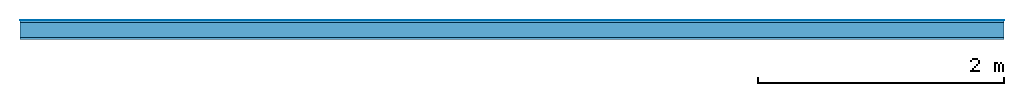
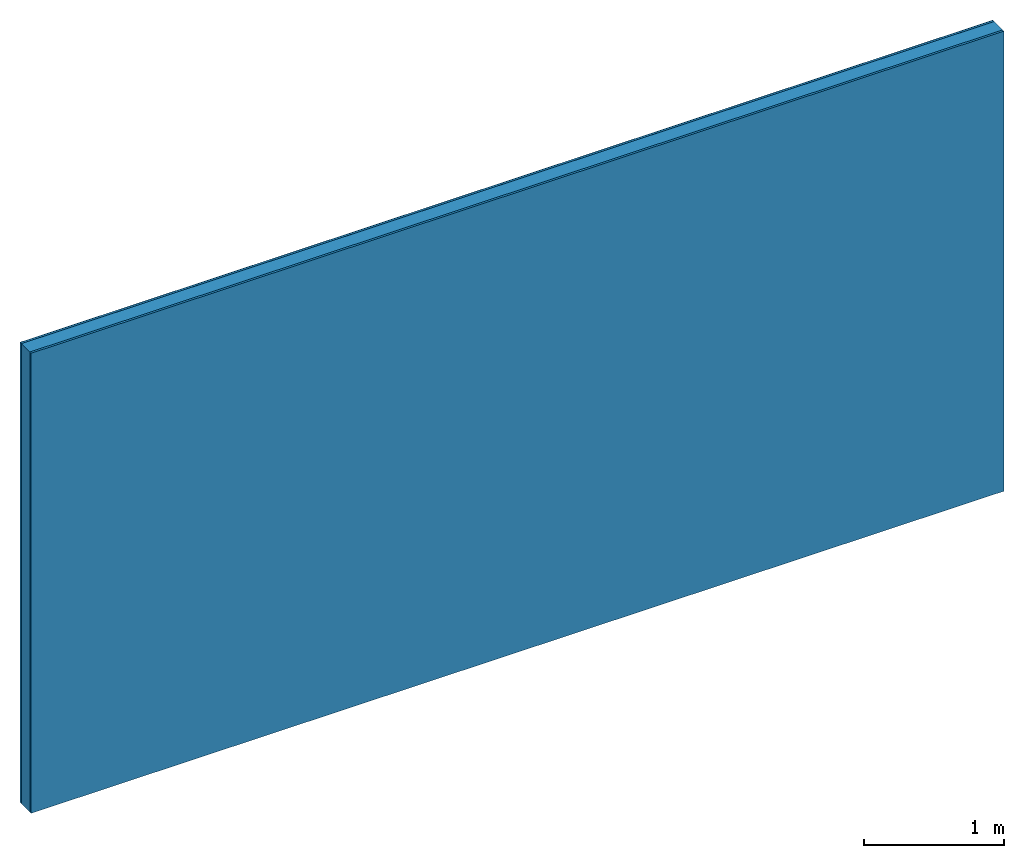
# One storey: 3 plates, 1 member, 1 element without a shape of its own.
"""IFC4 building model written with IfcOpenShell, lengths in metres."""

from ifc_helpers import new_model, si_unit, derived_unit, direction, frame, frame_2d, origin, origin_with_axes, place, context, project, spatial, rectangle, extrude, material, layer, layer_set, type_object, element, aggregate, save


model = new_model("IFC4")

# Units and contexts
plan_context = context("Plan", 3, precision=1e-05, world=origin(), true_north=direction((0.0, 1.0)))
model_context = context("Model", 3, precision=1e-05, world=origin(), true_north=direction((0.0, 1.0)))
ifc_project = project(units=[si_unit("LENGTHUNIT", "METRE"), derived_unit("SOUNDPRESSUREUNIT", [(si_unit("PRESSUREUNIT", "PASCAL", prefix="MICRO"), 0)]), si_unit("ENERGYUNIT", "JOULE", prefix="MEGA"), si_unit("MASSUNIT", "GRAM", prefix="KILO"), derived_unit("THERMALTRANSMITTANCEUNIT", [(si_unit("POWERUNIT", "WATT"), 1), (si_unit("AREAUNIT", "SQUARE_METRE"), -1), (si_unit("THERMODYNAMICTEMPERATUREUNIT", "KELVIN"), -1)]), derived_unit("AREADENSITYUNIT", [(si_unit("MASSUNIT", "GRAM", prefix="KILO"), 1), (si_unit("AREAUNIT", "SQUARE_METRE"), -1)]), derived_unit("USERDEFINED", [(si_unit("ENERGYUNIT", "JOULE", prefix="MEGA"), 1), (si_unit("AREAUNIT", "SQUARE_METRE"), -1)])], contexts=[plan_context, model_context])

# Site, building, storey
site = spatial("IfcSite", under=ifc_project)
building_placement = place(None, origin())
building = spatial("IfcBuilding", under=site, at=building_placement)
storey_placement = place(building_placement, origin())
storey = spatial("IfcBuildingStorey", under=building, at=storey_placement)

# Wall, member, plates
ifc_material_1 = material(Category="04.001")
ifc_layer_1 = layer(ifc_material_1, 0.003, Name="Surface")
ifc_material_2 = material(Category="03.007")
ifc_layer_2 = layer(ifc_material_2, 0.018, Name="1st layer")
ifc_material_3 = material(Name="of the art")
ifc_layer_3 = layer(ifc_material_3, 0.0, Name="Bond")
ifc_layer_4 = layer(None, 0.12, Name="Support")
ifc_layer_5 = layer(ifc_material_3, 0.0, Name="Bond")
ifc_layer_6 = layer(ifc_material_2, 0.018, Name="1st layer")
ifc_layer_set = layer_set([ifc_layer_1, ifc_layer_2, ifc_layer_3, ifc_layer_4, ifc_layer_5, ifc_layer_6])
wall_type = type_object("IfcWallType", Name="C0430", PredefinedType="NOTDEFINED", material=ifc_layer_set)
wall_placement = place(None, frame((0.0, 0.0, 0.0), z_axis=(0.0, -1.0, 0.0), x_axis=(1.0, 0.0, 0.0)))
wall = element("IfcWall", 1, at=wall_placement, inside=storey, type_object=wall_type, material=ifc_layer_set, Name="Wall #1")
ifc_material_4 = material(Name="Solid timber panel")
member_placement = place(wall_placement, origin())
member = element("IfcMember", 2, at=member_placement, material=ifc_material_4, Name="Support", context=plan_context, shape_type="SweptSolid", body=[
    extrude(rectangle(XDim=1.0, YDim=0.12, at=frame_2d((0.5, 0.06), x_axis=(1.0, 0.0))), frame((0.0, 4.0, 0.021), z_axis=(0.0, -1.0, 0.0), x_axis=(1.0, 0.0, 0.0)), (0.0, 0.0, 1.0), 4.0),
    extrude(rectangle(XDim=1.0, YDim=0.12, at=frame_2d((0.5, 0.06), x_axis=(1.0, 0.0))), frame((1.0, 4.0, 0.021), z_axis=(0.0, -1.0, 0.0), x_axis=(1.0, 0.0, 0.0)), (0.0, 0.0, 1.0), 4.0),
    extrude(rectangle(XDim=1.0, YDim=0.12, at=frame_2d((0.5, 0.06), x_axis=(1.0, 0.0))), frame((2.0, 4.0, 0.021), z_axis=(0.0, -1.0, 0.0), x_axis=(1.0, 0.0, 0.0)), (0.0, 0.0, 1.0), 4.0),
    extrude(rectangle(XDim=1.0, YDim=0.12, at=frame_2d((0.5, 0.06), x_axis=(1.0, 0.0))), frame((3.0, 4.0, 0.021), z_axis=(0.0, -1.0, 0.0), x_axis=(1.0, 0.0, 0.0)), (0.0, 0.0, 1.0), 4.0),
    extrude(rectangle(XDim=1.0, YDim=0.12, at=frame_2d((0.5, 0.06), x_axis=(1.0, 0.0))), frame((4.0, 4.0, 0.021), z_axis=(0.0, -1.0, 0.0), x_axis=(1.0, 0.0, 0.0)), (0.0, 0.0, 1.0), 4.0),
    extrude(rectangle(XDim=1.0, YDim=0.12, at=frame_2d((0.5, 0.06), x_axis=(1.0, 0.0))), frame((5.0, 4.0, 0.021), z_axis=(0.0, -1.0, 0.0), x_axis=(1.0, 0.0, 0.0)), (0.0, 0.0, 1.0), 4.0),
    extrude(rectangle(XDim=1.0, YDim=0.12, at=frame_2d((0.5, 0.06), x_axis=(1.0, 0.0))), frame((6.0, 4.0, 0.021), z_axis=(0.0, -1.0, 0.0), x_axis=(1.0, 0.0, 0.0)), (0.0, 0.0, 1.0), 4.0),
    extrude(rectangle(XDim=1.0, YDim=0.12, at=frame_2d((0.5, 0.06), x_axis=(1.0, 0.0))), frame((7.0, 4.0, 0.021), z_axis=(0.0, -1.0, 0.0), x_axis=(1.0, 0.0, 0.0)), (0.0, 0.0, 1.0), 4.0),
])
plate_1_placement = place(wall_placement, origin())
plate_1 = element("IfcPlate", 3, at=plate_1_placement, material=ifc_material_1, Name="Surface", context=plan_context, shape_type="SweptSolid", body=[
    extrude(rectangle(XDim=8.0, YDim=4.0, at=frame_2d((4.0, 2.0), x_axis=(1.0, 0.0))), origin_with_axes(), (0.0, 0.0, 1.0), 0.003),
])
plate_2_placement = place(wall_placement, origin())
plate_2 = element("IfcPlate", 4, at=plate_2_placement, material=ifc_material_2, Name="1st layer", context=plan_context, shape_type="SweptSolid", body=[
    extrude(rectangle(XDim=8.0, YDim=4.0, at=frame_2d((4.0, 2.0), x_axis=(1.0, 0.0))), frame((0.0, 0.0, 0.003), z_axis=(0.0, 0.0, 1.0), x_axis=(1.0, 0.0, 0.0)), (0.0, 0.0, 1.0), 0.018),
])
plate_3_placement = place(wall_placement, origin())
plate_3 = element("IfcPlate", 5, at=plate_3_placement, material=ifc_material_2, Name="1st layer", context=plan_context, shape_type="SweptSolid", body=[
    extrude(rectangle(XDim=8.0, YDim=4.0, at=frame_2d((4.0, 2.0), x_axis=(1.0, 0.0))), frame((0.0, 0.0, 0.141), z_axis=(0.0, 0.0, 1.0), x_axis=(1.0, 0.0, 0.0)), (0.0, 0.0, 1.0), 0.018),
])
aggregate(wall, [plate_1, plate_2, member, plate_3])

save(model, "model.ifc")
